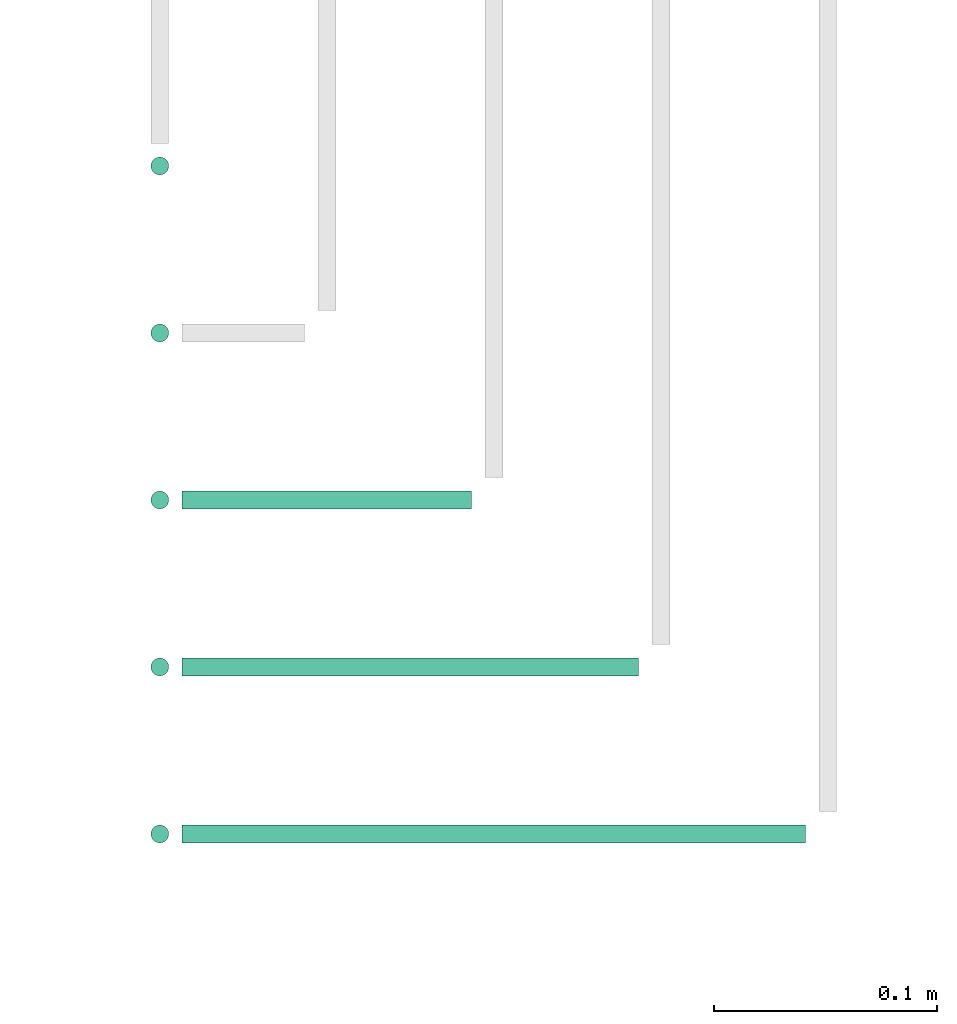
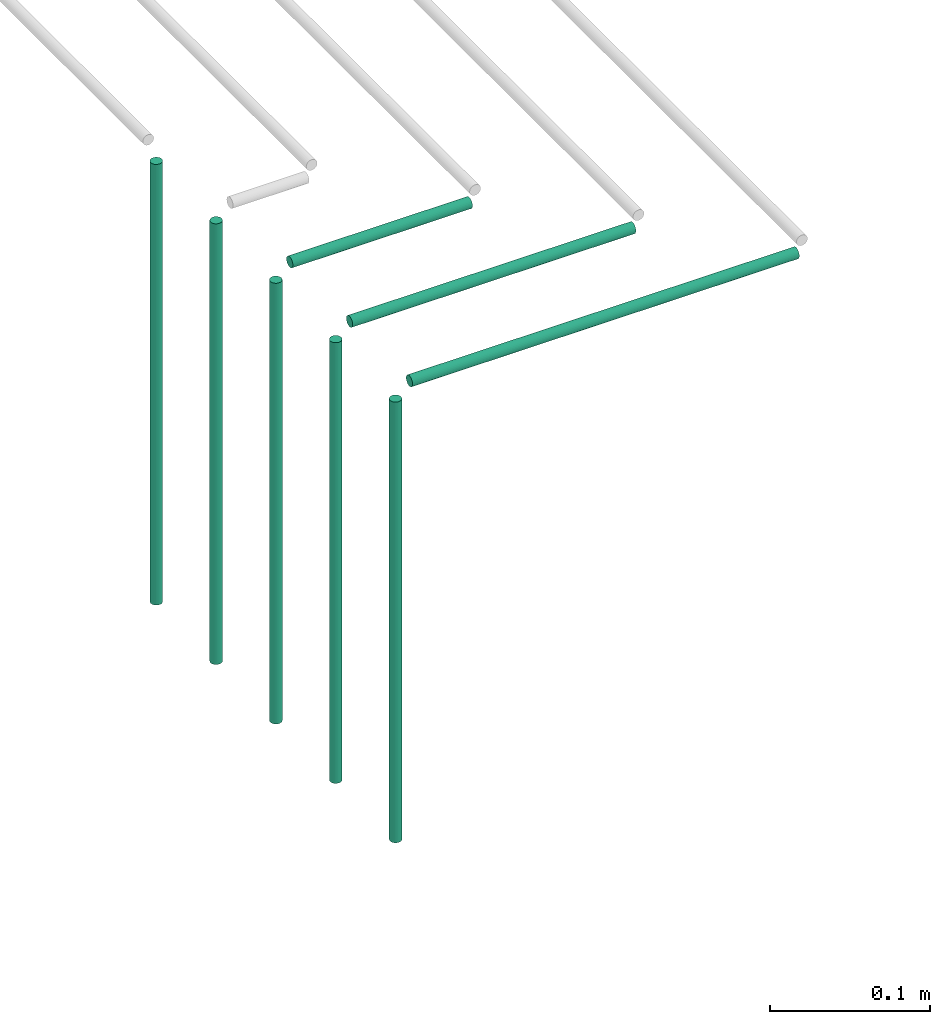
# One storey, part 55 of 89: 8 flow segments.
"""IFC2X3 building model written with IfcOpenShell, lengths in millimetres."""

import ifcopenshell
import ifcopenshell.guid

model = None  # the IFC model being written
_history = None  # IfcOwnerHistory: only IFC2X3 demands one
_inside = {}  # id of a spatial element -> (the spatial element, [elements in it])
_under = {}  # id of a project, library or spatial element -> (it, [spatial elements below it])
_declared = {}  # id of a project -> (the project, [libraries it declares])
_typed = {}  # id of a type object -> (the type object, [elements of that type])
_made_of = {}  # id of a material, layer set ... -> (it, [elements and type objects made of it])


def new_model(schema):
    """Start an empty IFC model of exactly this schema.

    Asked for "IFC4X3", IfcOpenShell would pick the latest addendum, in which some entities
    have other attributes; the version numbers below select the first issue.
    IFC2X3 requires an IfcOwnerHistory on every rooted entity: one is made here for all.
    """
    global model, _history
    if schema == "IFC4X3":
        model = ifcopenshell.file(schema_version=(4, 3, 0, 0))
    else:
        model = ifcopenshell.file(schema=schema)
    _inside.clear()
    _under.clear()
    _declared.clear()
    _typed.clear()
    _made_of.clear()
    _history = None
    if model.schema == "IFC2X3":
        org = make("IfcOrganization", Name="unknown")
        user = make(
            "IfcPersonAndOrganization",
            ThePerson=make("IfcPerson", FamilyName="unknown"),
            TheOrganization=org,
        )
        app = make(
            "IfcApplication",
            ApplicationDeveloper=org,
            Version="unknown",
            ApplicationFullName="unknown",
            ApplicationIdentifier="unknown",
        )
        _history = make(
            "IfcOwnerHistory",
            OwningUser=user,
            OwningApplication=app,
            ChangeAction="ADDED",
            CreationDate=0,
        )
    return model


def make(cls, **values):
    """One entity of the class cls with the attributes given. An attribute that is None is left unset."""
    return model.create_entity(
        cls, **{name: value for name, value in values.items() if value is not None}
    )


def entity(cls, *values):
    """Any entity or typed value of the class cls, its attributes in the order of the schema. None: left unset."""
    e = model.create_entity(cls)
    for i, value in enumerate(values):
        if value is not None:
            e[i] = value
    return e


def rooted(cls, **values):
    """An entity with a GlobalId (a new one), such as an element, a storey or a relation."""
    return make(cls, GlobalId=ifcopenshell.guid.new(), OwnerHistory=_history, **values)


def si_unit(unit_type, name, prefix=None):
    """IfcSIUnit, for example si_unit("LENGTHUNIT", "METRE", prefix="MILLI")."""
    return make("IfcSIUnit", UnitType=unit_type, Prefix=prefix, Name=name)


def converted_unit(unit_type, name, factor, base, dimensions=None, offset=None):
    """IfcConversionBasedUnit, such as the inch: factor (a typed value) times the base unit."""
    return make(
        "IfcConversionBasedUnit"
        if offset is None
        else "IfcConversionBasedUnitWithOffset",
        ConversionOffset=offset,
        Dimensions=None
        if dimensions is None
        else entity("IfcDimensionalExponents", *dimensions),
        UnitType=unit_type,
        Name=name,
        ConversionFactor=make(
            "IfcMeasureWithUnit", ValueComponent=factor, UnitComponent=base
        ),
    )


def derived_unit(unit_type, elements):
    """IfcDerivedUnit: a product of units, each with its exponent."""
    return make(
        "IfcDerivedUnit",
        Elements=[
            make("IfcDerivedUnitElement", Unit=unit, Exponent=power)
            for unit, power in elements
        ],
        UnitType=unit_type,
    )


def assignment(units):
    """IfcUnitAssignment: the units of a project."""
    return None if units is None else make("IfcUnitAssignment", Units=units)


def point(xyz):
    """IfcCartesianPoint."""
    return None if xyz is None else make("IfcCartesianPoint", Coordinates=xyz)


def direction(xyz):
    """IfcDirection."""
    return None if xyz is None else make("IfcDirection", DirectionRatios=xyz)


def frame(location, z_axis=None, x_axis=None):
    """IfcAxis2Placement3D, a coordinate frame: its origin and axes. An axis left out is left unset."""
    return make(
        "IfcAxis2Placement3D",
        Location=point(location),
        Axis=direction(z_axis),
        RefDirection=direction(x_axis),
    )


def frame_2d(location, x_axis=None):
    """IfcAxis2Placement2D, a coordinate frame in the plane: its origin and x axis."""
    return make(
        "IfcAxis2Placement2D", Location=point(location), RefDirection=direction(x_axis)
    )


def origin():
    """The frame at (0, 0, 0) with its axes left unset."""
    return frame((0.0, 0.0, 0.0))


def origin_2d_with_axis():
    """The frame at (0, 0) in the plane with the x axis (1, 0) written out."""
    return frame_2d((0.0, 0.0), x_axis=(1.0, 0.0))


def place(relative_to, where):
    """IfcLocalPlacement: puts the frame where relative to a parent placement (None: the world)."""
    return make(
        "IfcLocalPlacement", PlacementRelTo=relative_to, RelativePlacement=where
    )


def context(
    kind, dimensions, precision=None, world=None, true_north=None, identifier=None
):
    """IfcGeometricRepresentationContext, for example the 3D "Model" context."""
    return make(
        "IfcGeometricRepresentationContext",
        ContextIdentifier=identifier,
        ContextType=kind,
        CoordinateSpaceDimension=dimensions,
        Precision=precision,
        WorldCoordinateSystem=world,
        TrueNorth=true_north,
    )


def subcontext(parent, identifier, kind, view, scale=None):
    """IfcGeometricRepresentationSubContext, for example "Body" below "Model"."""
    return make(
        "IfcGeometricRepresentationSubContext",
        ContextIdentifier=identifier,
        ContextType=kind,
        ParentContext=parent,
        TargetScale=scale,
        TargetView=view,
    )


def project(units=None, contexts=None):
    """IfcProject with its units and contexts."""
    return rooted(
        "IfcProject",
        Name="project",
        RepresentationContexts=contexts,
        UnitsInContext=assignment(units),
    )


def spatial(cls, under=None, at=None, **own):
    """A site, building, storey or space (cls), placed at a placement, below another one or the project."""
    s = rooted(cls, ObjectPlacement=at, **own)
    if under is not None:
        _under.setdefault(under.id(), (under, []))[1].append(s)
    return s


def profile(cls, at=None, kind="AREA", **sizes):
    """A parametric profile (cls). Its sizes go by their IFC names, for example OverallWidth=200.0."""
    return make(cls, ProfileType=kind, Position=at, **sizes)


def circle(**sizes):
    """IfcCircleProfileDef."""
    return profile("IfcCircleProfileDef", **sizes)


def extrude(swept, where, along, depth):
    """IfcExtrudedAreaSolid: the profile swept, set in the frame where, extruded along a direction by depth."""
    return make(
        "IfcExtrudedAreaSolid",
        SweptArea=swept,
        Position=where,
        ExtrudedDirection=direction(along),
        Depth=depth,
    )


def shape(context_of_items, identifier, shape_type, items):
    """IfcShapeRepresentation: the items that make up one representation, for example the "Body"."""
    return make(
        "IfcShapeRepresentation",
        ContextOfItems=context_of_items,
        RepresentationIdentifier=identifier,
        RepresentationType=shape_type,
        Items=items,
    )


def made_of(thing, what):
    """Note that an element or type object is made of a material, layer set ...; save() writes the relation."""
    if what is not None:
        _made_of.setdefault(what.id(), (what, []))[1].append(thing)
    return thing


def type_object(cls, material=None, **own):
    """A type object (cls), such as IfcWallType, which elements share."""
    return made_of(rooted(cls, **own), material)


def element(
    cls,
    number,
    at=None,
    inside=None,
    cuts=None,
    type_object=None,
    material=None,
    context=None,
    identifier="Body",
    shape_type=None,
    held_by="IfcProductDefinitionShape",
    body=None,
    shapes=None,
    **own,
):
    """One element of the class cls, such as IfcWall. Its Tag is "e" and its number.

    at: its placement. inside: the storey or other place that contains it. cuts: it is an
    opening in that element (IfcRelVoidsElement). A single representation is given by context,
    identifier, shape_type and body (its items); several are given by shapes. held_by: the class
    of the entity that holds the representations. save() writes the other relations.
    """
    e = rooted(cls, Tag="e%d" % number, ObjectPlacement=at, **own)
    if body is not None:
        shapes = [shape(context, identifier, shape_type, body)]
    if shapes is not None:
        e.Representation = make(held_by, Representations=shapes)
    if inside is not None:
        _inside.setdefault(inside.id(), (inside, []))[1].append(e)
    if cuts is not None:
        rooted(
            "IfcRelVoidsElement", RelatingBuildingElement=cuts, RelatedOpeningElement=e
        )
    if type_object is not None:
        _typed.setdefault(type_object.id(), (type_object, []))[1].append(e)
    return made_of(e, material)


def aggregate(whole, parts):
    """IfcRelAggregates: a whole, such as a stair, and the parts it consists of."""
    return rooted("IfcRelAggregates", RelatingObject=whole, RelatedObjects=parts)


def save(model, path):
    """Write the relations noted so far, then the file.

    IfcRelAggregates (storeys below a building ...), IfcRelContainedInSpatialStructure (elements
    in a storey), IfcRelDefinesByType, IfcRelAssociatesMaterial and IfcRelDeclares: one each for
    every whole, place, type object, material and project.
    """
    for whole, parts in _under.values():
        aggregate(whole, parts)
    for where, things in _inside.values():
        rooted(
            "IfcRelContainedInSpatialStructure",
            RelatedElements=things,
            RelatingStructure=where,
        )
    for kind, things in _typed.values():
        rooted("IfcRelDefinesByType", RelatedObjects=things, RelatingType=kind)
    for what, things in _made_of.values():
        rooted("IfcRelAssociatesMaterial", RelatedObjects=things, RelatingMaterial=what)
    for by, libraries in _declared.values():
        rooted("IfcRelDeclares", RelatingContext=by, RelatedDefinitions=libraries)
    model.write(path)


model = new_model("IFC2X3")

# Units and contexts
model_context = context("Model", 3, precision=0.01, world=origin(), true_north=direction((6.12303176911189e-17, 1.0)))
body_context = subcontext(model_context, "Body", "Model", "MODEL_VIEW")
ifc_project = project(units=[si_unit("LENGTHUNIT", "METRE", prefix="MILLI"), si_unit("AREAUNIT", "SQUARE_METRE"), si_unit("VOLUMEUNIT", "CUBIC_METRE"), converted_unit("PLANEANGLEUNIT", "DEGREE", entity("IfcRatioMeasure", 0.0174532925199433), si_unit("PLANEANGLEUNIT", "RADIAN"), dimensions=[0, 0, 0, 0, 0, 0, 0]), si_unit("MASSUNIT", "GRAM", prefix="KILO"), derived_unit("MASSDENSITYUNIT", [(si_unit("MASSUNIT", "GRAM", prefix="KILO"), 1), (si_unit("LENGTHUNIT", "METRE"), -3)]), derived_unit("MOMENTOFINERTIAUNIT", [(si_unit("LENGTHUNIT", "METRE"), 4)]), si_unit("TIMEUNIT", "SECOND"), si_unit("FREQUENCYUNIT", "HERTZ"), si_unit("THERMODYNAMICTEMPERATUREUNIT", "DEGREE_CELSIUS"), derived_unit("THERMALTRANSMITTANCEUNIT", [(si_unit("MASSUNIT", "GRAM", prefix="KILO"), 1), (si_unit("THERMODYNAMICTEMPERATUREUNIT", "KELVIN"), -1), (si_unit("TIMEUNIT", "SECOND"), -3)]), derived_unit("VOLUMETRICFLOWRATEUNIT", [(si_unit("LENGTHUNIT", "METRE"), 3), (si_unit("TIMEUNIT", "SECOND"), -1)]), derived_unit("MASSFLOWRATEUNIT", [(si_unit("MASSUNIT", "GRAM", prefix="KILO"), 1), (si_unit("TIMEUNIT", "SECOND"), -1)]), derived_unit("ROTATIONALFREQUENCYUNIT", [(si_unit("TIMEUNIT", "SECOND"), -1)]), si_unit("ELECTRICCURRENTUNIT", "AMPERE"), si_unit("ELECTRICVOLTAGEUNIT", "VOLT"), si_unit("POWERUNIT", "WATT"), si_unit("FORCEUNIT", "NEWTON", prefix="KILO"), si_unit("ILLUMINANCEUNIT", "LUX"), si_unit("LUMINOUSFLUXUNIT", "LUMEN"), si_unit("LUMINOUSINTENSITYUNIT", "CANDELA"), derived_unit("USERDEFINED", [(si_unit("MASSUNIT", "GRAM", prefix="KILO"), -1), (si_unit("LENGTHUNIT", "METRE"), -2), (si_unit("TIMEUNIT", "SECOND"), 3), (si_unit("LUMINOUSFLUXUNIT", "LUMEN"), 1)]), derived_unit("LINEARVELOCITYUNIT", [(si_unit("LENGTHUNIT", "METRE"), 1), (si_unit("TIMEUNIT", "SECOND"), -1)]), si_unit("PRESSUREUNIT", "PASCAL"), derived_unit("USERDEFINED", [(si_unit("LENGTHUNIT", "METRE"), -2), (si_unit("MASSUNIT", "GRAM", prefix="KILO"), 1), (si_unit("TIMEUNIT", "SECOND"), -2)]), derived_unit("LINEARFORCEUNIT", [(si_unit("MASSUNIT", "GRAM", prefix="KILO"), 1), (si_unit("LENGTHUNIT", "METRE"), 1), (si_unit("TIMEUNIT", "SECOND"), -2), (si_unit("LENGTHUNIT", "METRE"), -1)]), derived_unit("PLANARFORCEUNIT", [(si_unit("MASSUNIT", "GRAM", prefix="KILO"), 1), (si_unit("LENGTHUNIT", "METRE"), 1), (si_unit("TIMEUNIT", "SECOND"), -2), (si_unit("LENGTHUNIT", "METRE"), -2)])], contexts=[model_context])

# Site, building, storey
site_placement = place(None, frame((0.0, -0.00077364408347762, 0.0)))
site = spatial("IfcSite", under=ifc_project, at=site_placement, CompositionType="ELEMENT")
building_placement = place(site_placement, origin())
building = spatial("IfcBuilding", under=site, at=building_placement, CompositionType="ELEMENT")
storey_placement = place(building_placement, frame((0.0, 0.0, 24000.0)))
storey = spatial("IfcBuildingStorey", under=building, at=storey_placement, CompositionType="ELEMENT", Elevation=24000.0)

# Flow segments
pipe_segment_type = type_object("IfcPipeSegmentType", PredefinedType="NOTDEFINED")
flow_segment_1_placement = place(storey_placement, frame((53688.0048908762, 16961.4047204552, 2727.70394187732)))
element("IfcFlowSegment", 1, at=flow_segment_1_placement, inside=storey, type_object=pipe_segment_type, context=body_context, shape_type="SweptSolid", body=[
    extrude(circle(Radius=4.0, at=origin_2d_with_axis()), frame((5.59527223591499, 5.59527223591499, 0.0)), (0.0, 0.0, 1.0), 337.296058481597),
])
flow_segment_2_placement = place(storey_placement, frame((53688.0048908762, 16886.4047204552, 2727.70394187732)))
element("IfcFlowSegment", 2, at=flow_segment_2_placement, inside=storey, type_object=pipe_segment_type, context=body_context, shape_type="SweptSolid", body=[
    extrude(circle(Radius=4.0, at=origin_2d_with_axis()), frame((5.59527223591499, 5.59527223591499, 0.0)), (0.0, 0.0, 1.0), 337.296058122682),
])
flow_segment_3_placement = place(storey_placement, frame((53703.6001631122, 16811.4047204552, 3069.40472776409)))
element("IfcFlowSegment", 3, at=flow_segment_3_placement, inside=storey, type_object=pipe_segment_type, context=body_context, shape_type="SweptSolid", body=[
    extrude(circle(Radius=4.0, at=frame_2d((-2.16573425859679e-12, 0.0), x_axis=(1.0, 0.0))), frame((0.0, 5.59527223591499, 5.59527223591499), z_axis=(1.0, 0.0, 0.0), x_axis=(0.0, 1.0, 0.0)), (0.0, 0.0, 1.0), 130.016020065922),
])
flow_segment_4_placement = place(storey_placement, frame((53688.0048908762, 16811.4047204552, 2727.70394187732)))
element("IfcFlowSegment", 4, at=flow_segment_4_placement, inside=storey, type_object=pipe_segment_type, context=body_context, shape_type="SweptSolid", body=[
    extrude(circle(Radius=4.0, at=origin_2d_with_axis()), frame((5.59527223591499, 5.59527223591499, 0.0)), (0.0, 0.0, 1.0), 337.296058122682),
])
flow_segment_5_placement = place(storey_placement, frame((53703.6001631122, 16736.4047204552, 3069.40472776409)))
element("IfcFlowSegment", 5, at=flow_segment_5_placement, inside=storey, type_object=pipe_segment_type, context=body_context, shape_type="SweptSolid", body=[
    extrude(circle(Radius=4.0, at=frame_2d((-2.16573425859679e-12, 0.0), x_axis=(1.0, 0.0))), frame((0.0, 5.59527223591499, 5.59527223591499), z_axis=(1.0, 0.0, 0.0), x_axis=(0.0, 1.0, 0.0)), (0.0, 0.0, 1.0), 205.016020065922),
])
flow_segment_6_placement = place(storey_placement, frame((53688.0048908762, 16736.4047204552, 2727.70394187732)))
element("IfcFlowSegment", 6, at=flow_segment_6_placement, inside=storey, type_object=pipe_segment_type, context=body_context, shape_type="SweptSolid", body=[
    extrude(circle(Radius=4.0, at=origin_2d_with_axis()), frame((5.59527223591499, 5.59527223591499, 0.0)), (0.0, 0.0, 1.0), 337.296058122687),
])
flow_segment_7_placement = place(storey_placement, frame((53703.6001631122, 16661.4047204552, 3069.40472776409)))
element("IfcFlowSegment", 7, at=flow_segment_7_placement, inside=storey, type_object=pipe_segment_type, context=body_context, shape_type="SweptSolid", body=[
    extrude(circle(Radius=4.0, at=origin_2d_with_axis()), frame((0.0, 5.59527223591499, 5.59527223591499), z_axis=(1.0, 0.0, 0.0), x_axis=(0.0, 1.0, 0.0)), (0.0, 0.0, 1.0), 280.016020065931),
])
flow_segment_8_placement = place(storey_placement, frame((53688.0048908762, 16661.4047204552, 2727.70394187732)))
element("IfcFlowSegment", 8, at=flow_segment_8_placement, inside=storey, type_object=pipe_segment_type, context=body_context, shape_type="SweptSolid", body=[
    extrude(circle(Radius=4.0, at=origin_2d_with_axis()), frame((5.59527223591499, 5.59527223591499, 0.0)), (0.0, 0.0, 1.0), 337.296058122687),
])

save(model, "model.ifc")
